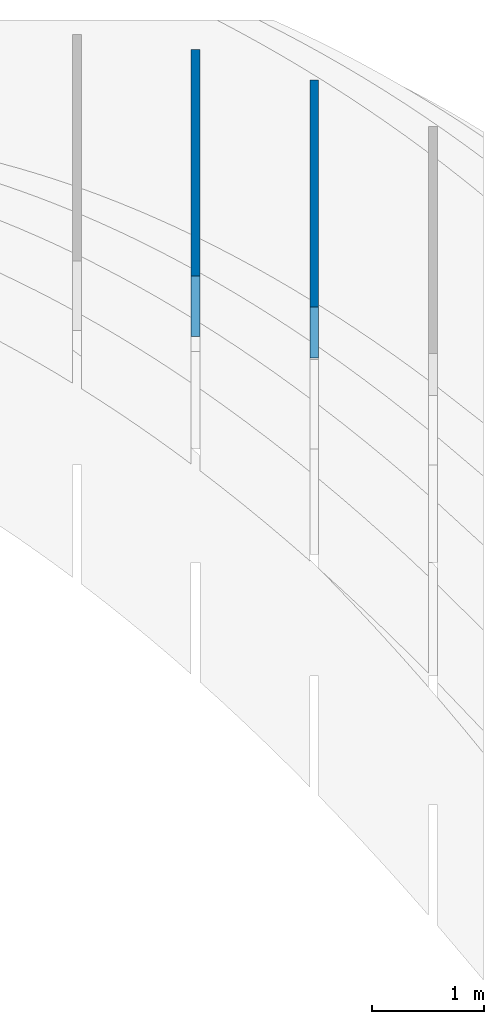
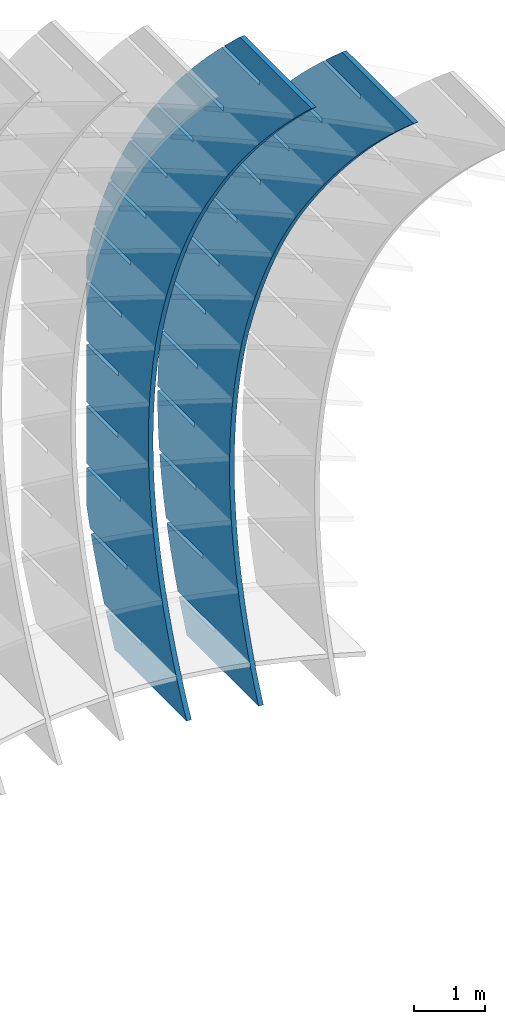
# Not in any storey, part 8 of 9: 2 walls.
"""IFC2X3 building model written with IfcOpenShell, lengths in metres."""

from ifc_helpers import new_model, entity, si_unit, point, direction, frame, frame_2d, origin_with_axes, place, context, project, spatial, polyline, circle_curve, parameter, trimmed, segment, composite_curve, outline, extrude, material, type_object, element, save


model = new_model("IFC2X3")

# Units and contexts
model_context = context("Model", 3, precision=2.54e-06, world=origin_with_axes(), true_north=direction((0.0, 1.0)), identifier="Body")
ifc_project = project(units=[si_unit("LENGTHUNIT", "METRE"), si_unit("AREAUNIT", "SQUARE_METRE"), si_unit("VOLUMEUNIT", "CUBIC_METRE"), si_unit("PLANEANGLEUNIT", "RADIAN")], contexts=[model_context])

# Building
building_placement = place(None, origin_with_axes())
building = spatial("IfcBuilding", under=ifc_project, at=building_placement, Name="Building", CompositionType="ELEMENT")

# Walls
ifc_material = material(Name="MATERIAL")
wall_type = type_object("IfcWallType", Name="WALL", PredefinedType="NOTDEFINED", material=ifc_material)
wall_1_placement = place(None, origin_with_axes())
cartesian_point_1 = entity("IfcCartesianPoint", [3.33628428857508, 0.660800836705799])
cartesian_point_2 = entity("IfcCartesianPoint", [5.89989121669628, 2.3739950625877])
cartesian_point_3 = entity("IfcCartesianPoint", [7.96759101893719, 5.14737190911829])
cartesian_point_4 = entity("IfcCartesianPoint", [9.64855568825393, 9.34702306752498])
cartesian_point_5 = entity("IfcCartesianPoint", [10.5095055595742, 7.50642824001081])
cartesian_point_6 = entity("IfcCartesianPoint", [10.3316593318507, 6.9182703694655])
cartesian_point_7 = entity("IfcCartesianPoint", [9.91130915650263, 7.81692240980345])
cartesian_point_8 = entity("IfcCartesianPoint", [9.83998610693644, 7.7835606022898])
cartesian_point_9 = entity("IfcCartesianPoint", [10.2966458160783, 6.80728367075111])
cartesian_point_10 = entity("IfcCartesianPoint", [9.83148702993814, 5.48062696650699])
cartesian_point_11 = entity("IfcCartesianPoint", [9.4089005920243, 6.38405983491734])
cartesian_point_12 = entity("IfcCartesianPoint", [9.33757754245811, 6.35069802740369])
cartesian_point_13 = entity("IfcCartesianPoint", [9.79200104866843, 5.37920179644498])
cartesian_point_14 = entity("IfcCartesianPoint", [9.2709518727035, 4.1720312154331])
cartesian_point_15 = entity("IfcCartesianPoint", [8.84613322657731, 5.08023624424941])
cartesian_point_16 = entity("IfcCartesianPoint", [8.77481017701111, 5.04687443673576])
cartesian_point_17 = entity("IfcCartesianPoint", [9.22700147500962, 4.08015036618439])
cartesian_point_18 = entity("IfcCartesianPoint", [8.65019291620515, 2.992185833119])
cartesian_point_19 = entity("IfcCartesianPoint", [8.22314206186706, 3.90516302234252])
cartesian_point_20 = entity("IfcCartesianPoint", [8.15181901230087, 3.87180121482886])
cartesian_point_21 = entity("IfcCartesianPoint", [8.60177810208755, 2.90984930468483])
cartesian_point_22 = entity("IfcCartesianPoint", [7.96921016044345, 1.94109081956572])
cartesian_point_23 = entity("IfcCartesianPoint", [7.53992709789357, 2.85884016919665])
cartesian_point_24 = entity("IfcCartesianPoint", [7.46860404832738, 2.825478361683])
cartesian_point_25 = entity("IfcCartesianPoint", [7.91633092990223, 1.8682986119463])
cartesian_point_26 = entity("IfcCartesianPoint", [7.22800360541863, 1.01874617477364])
cartesian_point_27 = entity("IfcCartesianPoint", [6.79648833465683, 1.94126768481181])
cartesian_point_28 = entity("IfcCartesianPoint", [6.72516528509063, 1.90790587729816])
cartesian_point_29 = entity("IfcCartesianPoint", [7.17065995845367, 0.9554982879688])
cartesian_point_30 = entity("IfcCartesianPoint", [6.42657325113035, 0.225151898742356])
cartesian_point_31 = entity("IfcCartesianPoint", [5.99282577215684, 1.152445569188])
cartesian_point_32 = entity("IfcCartesianPoint", [5.92150272259064, 1.11908376167435])
cartesian_point_33 = entity("IfcCartesianPoint", [6.36476518774186, 0.17144833275233])
cartesian_point_34 = entity("IfcCartesianPoint", [5.56491909757877, -0.43969200852788])
cartesian_point_35 = entity("IfcCartesianPoint", [5.1289394103936, 0.492373822325222])
cartesian_point_36 = entity("IfcCartesianPoint", [5.0576163608274, 0.45901201481157])
cartesian_point_37 = entity("IfcCartesianPoint", [5.4986466177668, -0.483851253703113])
cartesian_point_38 = entity("IfcCartesianPoint", [4.64304114476423, -0.975785547036886])
cartesian_point_39 = entity("IfcCartesianPoint", [4.20482924936711, -0.0389475557765274])
cartesian_point_40 = entity("IfcCartesianPoint", [4.13350619980092, -0.0723093632901794])
cartesian_point_41 = entity("IfcCartesianPoint", [4.57230424852848, -1.01040047139752])
cartesian_point_42 = entity("IfcCartesianPoint", [3.66093939268637, -1.38312871678492])
cartesian_point_43 = entity("IfcCartesianPoint", [3.22049528907738, -0.441518565117246])
cartesian_point_44 = entity("IfcCartesianPoint", [3.14917223951118, -0.474880372630899])
cartesian_point_45 = entity("IfcCartesianPoint", [3.58573808002693, -1.4081993203309])
cartesian_point_46 = entity("IfcCartesianPoint", [2.61861384134521, -1.66172151777196])
cartesian_point_47 = entity("IfcCartesianPoint", [2.17593752952439, -0.715339205696935])
cartesian_point_48 = entity("IfcCartesianPoint", [2.10461447995819, -0.748701013210588])
cartesian_point_49 = entity("IfcCartesianPoint", [2.53894811226212, -1.67724780050326])
cartesian_point_50 = entity("IfcCartesianPoint", [1.51600977615583, -1.81144697758717])
cartesian_point_51 = entity("IfcCartesianPoint", [1.07107023636221, -0.860226189035098])
cartesian_point_52 = entity("IfcCartesianPoint", [0.99974718679601, -0.893587996548751])
cartesian_point_53 = entity("IfcCartesianPoint", [1.4318204023056, -1.81730231728527])
cartesian_point_54 = entity("IfcCartesianPoint", [0.860949871320121, -1.84059482751472])
element("IfcWall", 1, at=wall_1_placement, inside=building, type_object=wall_type, context=model_context, shape_type="SweptSolid", body=[
    extrude(entity("IfcArbitraryOpenProfileDef", "AREA", None, entity("IfcCompositeCurve", [entity("IfcCompositeCurveSegment", "CONTINUOUS", True, entity("IfcTrimmedCurve", entity("IfcCircle", entity("IfcAxis2Placement2D", entity("IfcCartesianPoint", [0.0, 8.752599843585]), entity("IfcDirection", [0.0, -1.0])), 8.752599843585), [entity("IfcParameterValue", 0.0), entity("IfcCartesianPoint", [0.0, -8.752599843585])], [entity("IfcParameterValue", 0.391068405592432), cartesian_point_1], True, "PARAMETER")), entity("IfcCompositeCurveSegment", "CONTINUOUS", True, entity("IfcTrimmedCurve", entity("IfcCircle", entity("IfcAxis2Placement2D", entity("IfcCartesianPoint", [0.0936429203069245, 8.28773253450056]), entity("IfcDirection", [0.39126281, -0.92027899])), 8.2876299486663), [entity("IfcParameterValue", 0.0), cartesian_point_1], [entity("IfcParameterValue", 0.374223583295173), cartesian_point_2], True, "PARAMETER")), entity("IfcCompositeCurveSegment", "CONTINUOUS", True, entity("IfcTrimmedCurve", entity("IfcCircle", entity("IfcAxis2Placement2D", entity("IfcCartesianPoint", [-2.30291342409356, 10.6471002357322]), entity("IfcDirection", [0.70408324, -0.71011745])), 11.6503336081365), [entity("IfcParameterValue", 0.0), cartesian_point_2], [entity("IfcParameterValue", 0.298031940766196), cartesian_point_3], True, "PARAMETER")), entity("IfcCompositeCurveSegment", "CONTINUOUS", True, entity("IfcTrimmedCurve", entity("IfcCircle", entity("IfcAxis2Placement2D", entity("IfcCartesianPoint", [-9.94868855610094, 14.7548339304275]), entity("IfcDirection", [0.8812863, -0.47258275])), 20.3296925776517), [entity("IfcParameterValue", 0.0), cartesian_point_3], [entity("IfcParameterValue", 0.22297224709584), cartesian_point_4], True, "PARAMETER")), entity("IfcCompositeCurveSegment", "CONTINUOUS", True, entity("IfcPolyline", [cartesian_point_4, cartesian_point_5])), entity("IfcCompositeCurveSegment", "CONTINUOUS", True, entity("IfcPolyline", [cartesian_point_5, cartesian_point_6])), entity("IfcCompositeCurveSegment", "CONTINUOUS", True, entity("IfcPolyline", [cartesian_point_6, cartesian_point_7])), entity("IfcCompositeCurveSegment", "CONTINUOUS", True, entity("IfcPolyline", [cartesian_point_7, cartesian_point_8])), entity("IfcCompositeCurveSegment", "CONTINUOUS", True, entity("IfcPolyline", [cartesian_point_8, cartesian_point_9])), entity("IfcCompositeCurveSegment", "CONTINUOUS", True, entity("IfcTrimmedCurve", entity("IfcCircle", entity("IfcAxis2Placement2D", entity("IfcCartesianPoint", [-11.5769992031336, 13.7318503522371]), entity("IfcDirection", [0.93309434, -0.35963168])), 22.9435387452076), [entity("IfcParameterValue", 0.0612835566242395), cartesian_point_9], [entity("IfcParameterValue", 0.0), cartesian_point_10], False, "PARAMETER")), entity("IfcCompositeCurveSegment", "CONTINUOUS", True, entity("IfcPolyline", [cartesian_point_10, cartesian_point_11])), entity("IfcCompositeCurveSegment", "CONTINUOUS", True, entity("IfcPolyline", [cartesian_point_11, cartesian_point_12])), entity("IfcCompositeCurveSegment", "CONTINUOUS", True, entity("IfcPolyline", [cartesian_point_12, cartesian_point_13])), entity("IfcCompositeCurveSegment", "CONTINUOUS", True, entity("IfcTrimmedCurve", entity("IfcCircle", entity("IfcAxis2Placement2D", entity("IfcCartesianPoint", [-7.87481118422335, 12.2886655949803]), entity("IfcDirection", [0.90384066, -0.42786921])), 18.9698957418201), [entity("IfcParameterValue", 0.0693247809412823), cartesian_point_13], [entity("IfcParameterValue", 0.0), cartesian_point_14], False, "PARAMETER")), entity("IfcCompositeCurveSegment", "CONTINUOUS", True, entity("IfcPolyline", [cartesian_point_14, cartesian_point_15])), entity("IfcCompositeCurveSegment", "CONTINUOUS", True, entity("IfcPolyline", [cartesian_point_15, cartesian_point_16])), entity("IfcCompositeCurveSegment", "CONTINUOUS", True, entity("IfcPolyline", [cartesian_point_16, cartesian_point_17])), entity("IfcCompositeCurveSegment", "CONTINUOUS", True, entity("IfcTrimmedCurve", entity("IfcCircle", entity("IfcAxis2Placement2D", entity("IfcCartesianPoint", [-4.82060400145122, 10.8309141796685]), entity("IfcDirection", [0.8643156, -0.50294984])), 15.5855071039648), [entity("IfcParameterValue", 0.0790306201356145), cartesian_point_17], [entity("IfcParameterValue", 0.0), cartesian_point_18], False, "PARAMETER")), entity("IfcCompositeCurveSegment", "CONTINUOUS", True, entity("IfcPolyline", [cartesian_point_18, cartesian_point_19])), entity("IfcCompositeCurveSegment", "CONTINUOUS", True, entity("IfcPolyline", [cartesian_point_19, cartesian_point_20])), entity("IfcCompositeCurveSegment", "CONTINUOUS", True, entity("IfcPolyline", [cartesian_point_20, cartesian_point_21])), entity("IfcCompositeCurveSegment", "CONTINUOUS", True, entity("IfcTrimmedCurve", entity("IfcCircle", entity("IfcAxis2Placement2D", entity("IfcCartesianPoint", [-2.52920239324131, 9.48711692777493]), entity("IfcDirection", [0.81200466, -0.58365094])), 12.9290052275162), [entity("IfcParameterValue", 0.0895181356163804), cartesian_point_21], [entity("IfcParameterValue", 0.0), cartesian_point_22], False, "PARAMETER")), entity("IfcCompositeCurveSegment", "CONTINUOUS", True, entity("IfcPolyline", [cartesian_point_22, cartesian_point_23])), entity("IfcCompositeCurveSegment", "CONTINUOUS", True, entity("IfcPolyline", [cartesian_point_23, cartesian_point_24])), entity("IfcCompositeCurveSegment", "CONTINUOUS", True, entity("IfcPolyline", [cartesian_point_24, cartesian_point_25])), entity("IfcCompositeCurveSegment", "CONTINUOUS", True, entity("IfcTrimmedCurve", entity("IfcCircle", entity("IfcAxis2Placement2D", entity("IfcCartesianPoint", [-0.897231518059096, 8.30562807521818]), entity("IfcDirection", [0.74446977, -0.66765617])), 10.9141235856491), [entity("IfcParameterValue", 0.100224490194484), cartesian_point_25], [entity("IfcParameterValue", 0.0), cartesian_point_26], False, "PARAMETER")), entity("IfcCompositeCurveSegment", "CONTINUOUS", True, entity("IfcPolyline", [cartesian_point_26, cartesian_point_27])), entity("IfcCompositeCurveSegment", "CONTINUOUS", True, entity("IfcPolyline", [cartesian_point_27, cartesian_point_28])), entity("IfcCompositeCurveSegment", "CONTINUOUS", True, entity("IfcPolyline", [cartesian_point_28, cartesian_point_29])), entity("IfcCompositeCurveSegment", "CONTINUOUS", True, entity("IfcTrimmedCurve", entity("IfcCircle", entity("IfcAxis2Placement2D", entity("IfcCartesianPoint", [0.178683465632477, 7.33480185791517]), entity("IfcDirection", [0.66011554, -0.75116408])), 9.4648428044894), [entity("IfcParameterValue", 0.110213642371302), cartesian_point_29], [entity("IfcParameterValue", 0.0), cartesian_point_30], False, "PARAMETER")), entity("IfcCompositeCurveSegment", "CONTINUOUS", True, entity("IfcPolyline", [cartesian_point_30, cartesian_point_31])), entity("IfcCompositeCurveSegment", "CONTINUOUS", True, entity("IfcPolyline", [cartesian_point_31, cartesian_point_32])), entity("IfcCompositeCurveSegment", "CONTINUOUS", True, entity("IfcPolyline", [cartesian_point_32, cartesian_point_33])), entity("IfcCompositeCurveSegment", "CONTINUOUS", True, entity("IfcTrimmedCurve", entity("IfcCircle", entity("IfcAxis2Placement2D", entity("IfcCartesianPoint", [0.801917399369377, 6.62299251178352]), entity("IfcDirection", [0.5591252, -0.82908324])), 8.51866760770673), [entity("IfcParameterValue", 0.118233031779909), cartesian_point_33], [entity("IfcParameterValue", 0.0), cartesian_point_34], False, "PARAMETER")), entity("IfcCompositeCurveSegment", "CONTINUOUS", True, entity("IfcPolyline", [cartesian_point_34, cartesian_point_35])), entity("IfcCompositeCurveSegment", "CONTINUOUS", True, entity("IfcPolyline", [cartesian_point_35, cartesian_point_36])), entity("IfcCompositeCurveSegment", "CONTINUOUS", True, entity("IfcPolyline", [cartesian_point_36, cartesian_point_37])), entity("IfcCompositeCurveSegment", "CONTINUOUS", True, entity("IfcTrimmedCurve", entity("IfcCircle", entity("IfcAxis2Placement2D", entity("IfcCartesianPoint", [1.07584512468748, 6.21855427274113]), entity("IfcDirection", [0.44422497, -0.89591527])), 8.03015646722372), [entity("IfcParameterValue", 0.122982293439985), cartesian_point_37], [entity("IfcParameterValue", 0.0), cartesian_point_38], False, "PARAMETER")), entity("IfcCompositeCurveSegment", "CONTINUOUS", True, entity("IfcPolyline", [cartesian_point_38, cartesian_point_39])), entity("IfcCompositeCurveSegment", "CONTINUOUS", True, entity("IfcPolyline", [cartesian_point_39, cartesian_point_40])), entity("IfcCompositeCurveSegment", "CONTINUOUS", True, entity("IfcPolyline", [cartesian_point_40, cartesian_point_41])), entity("IfcCompositeCurveSegment", "CONTINUOUS", True, entity("IfcTrimmedCurve", entity("IfcCircle", entity("IfcAxis2Placement2D", entity("IfcCartesianPoint", [1.10384148312315, 6.1698413767053]), entity("IfcDirection", [0.32067584, -0.947189])), 7.97408972562074), [entity("IfcParameterValue", 0.123558271913987), cartesian_point_41], [entity("IfcParameterValue", 0.0), cartesian_point_42], False, "PARAMETER")), entity("IfcCompositeCurveSegment", "CONTINUOUS", True, entity("IfcPolyline", [cartesian_point_42, cartesian_point_43])), entity("IfcCompositeCurveSegment", "CONTINUOUS", True, entity("IfcPolyline", [cartesian_point_43, cartesian_point_44])), entity("IfcCompositeCurveSegment", "CONTINUOUS", True, entity("IfcPolyline", [cartesian_point_44, cartesian_point_45])), entity("IfcCompositeCurveSegment", "CONTINUOUS", True, entity("IfcTrimmedCurve", entity("IfcCircle", entity("IfcAxis2Placement2D", entity("IfcCartesianPoint", [0.989281316212527, 6.5252080595934]), entity("IfcDirection", [0.19518839, -0.98076577])), 8.34748706990283), [entity("IfcParameterValue", 0.119844445167163), cartesian_point_45], [entity("IfcParameterValue", 0.0), cartesian_point_46], False, "PARAMETER")), entity("IfcCompositeCurveSegment", "CONTINUOUS", True, entity("IfcPolyline", [cartesian_point_46, cartesian_point_47])), entity("IfcCompositeCurveSegment", "CONTINUOUS", True, entity("IfcPolyline", [cartesian_point_47, cartesian_point_48])), entity("IfcCompositeCurveSegment", "CONTINUOUS", True, entity("IfcPolyline", [cartesian_point_48, cartesian_point_49])), entity("IfcCompositeCurveSegment", "CONTINUOUS", True, entity("IfcTrimmedCurve", entity("IfcCircle", entity("IfcAxis2Placement2D", entity("IfcCartesianPoint", [0.841571319033154, 7.2952786297832]), entity("IfcDirection", [0.07385711, -0.99726883])), 9.13166570349469), [entity("IfcParameterValue", 0.113041050513726), cartesian_point_49], [entity("IfcParameterValue", 0.0), cartesian_point_50], False, "PARAMETER")), entity("IfcCompositeCurveSegment", "CONTINUOUS", True, entity("IfcPolyline", [cartesian_point_50, cartesian_point_51])), entity("IfcCompositeCurveSegment", "CONTINUOUS", True, entity("IfcPolyline", [cartesian_point_51, cartesian_point_52])), entity("IfcCompositeCurveSegment", "CONTINUOUS", True, entity("IfcPolyline", [cartesian_point_52, cartesian_point_53])), entity("IfcCompositeCurveSegment", "CONTINUOUS", True, entity("IfcPolyline", [cartesian_point_53, cartesian_point_54])), entity("IfcCompositeCurveSegment", "CONTINUOUS", True, entity("IfcPolyline", [cartesian_point_54, entity("IfcCartesianPoint", [0.0, 0.0])]))], "UNKNOWN")), frame((17.3363837134573, -0.590090071613778, -6.51240052652896), z_axis=(1.0, 0.0, 0.0), x_axis=(0.0, 0.4236958, 0.90580454)), (0.0, 0.0, 1.0), 0.07874),
])
wall_2_placement = place(None, origin_with_axes())
element("IfcWall", 2, at=wall_2_placement, inside=building, type_object=wall_type, context=model_context, shape_type="SweptSolid", body=[
    extrude(outline(composite_curve([segment(trimmed(circle_curve(frame_2d((0.0, 9.20461752347333), x_axis=(0.0, -1.0)), 9.20461752347333), [parameter(0.0), point((0.0, -9.20461752347333))], [parameter(0.378223886313724), point((3.39899345067959, 0.650564257584139))], True, "PARAMETER"), True, "CONTINUOUS"), segment(trimmed(circle_curve(frame_2d((0.329804616442884, 8.14417270659547), x_axis=(0.37901595, -0.92539014)), 8.09778288714246), [parameter(0.0), point((3.39899345067959, 0.650564257584139))], [parameter(0.380067485400107), point((5.95997730454182, 2.32392845145617))], True, "PARAMETER"), True, "CONTINUOUS"), segment(trimmed(circle_curve(frame_2d((-1.56899167584664, 10.0081173696648), x_axis=(0.69985574, -0.71428422)), 10.7578870248005), [parameter(0.0), point((5.95997730454182, 2.32392845145617))], [parameter(0.314335542493863), point((7.966906277324, 5.02827967501169))], True, "PARAMETER"), True, "CONTINUOUS"), segment(trimmed(circle_curve(frame_2d((-5.87202203403603, 12.412597620723), x_axis=(0.88225879, -0.47076473)), 15.6857925630271), [parameter(0.0), point((7.966906277324, 5.02827967501169))], [parameter(0.121982619582007), point((8.76260018330957, 6.7670754229196))], True, "PARAMETER"), True, "CONTINUOUS"), segment(trimmed(circle_curve(frame_2d((-11.2006346012153, 14.4600525420821), x_axis=(0.93311348, -0.35958204)), 21.3942197805393), [parameter(0.0), point((8.76260018330957, 6.7670754229196))], [parameter(0.115561710265485), point((9.51648505550891, 9.12024045297327))], True, "PARAMETER"), True, "CONTINUOUS"), segment(polyline([(9.51648505550891, 9.12024045297327), (10.4783858907177, 7.33033241532919)]), True, "CONTINUOUS"), segment(polyline([(10.4783858907177, 7.33033241532919), (10.320502907352, 6.75738222265186)]), True, "CONTINUOUS"), segment(polyline([(10.320502907352, 6.75738222265186), (9.84961745893748, 7.63360731579705)]), True, "CONTINUOUS"), segment(polyline([(9.84961745893748, 7.63360731579705), (9.78025852247875, 7.59633365843272)]), True, "CONTINUOUS"), segment(polyline([(9.78025852247875, 7.59633365843272), (10.2892170446355, 6.64926207237004)]), True, "CONTINUOUS"), segment(trimmed(circle_curve(frame_2d((-9.64067057274752, 12.4392339366316), x_axis=(0.9399691, -0.34125958)), 20.7538958904215), [parameter(0.0655223084688722), point((10.2892170446355, 6.64926207237004))], [parameter(0.0), point((9.86735019231572, 5.35676823178572))], False, "PARAMETER"), True, "CONTINUOUS"), segment(polyline([(9.86735019231572, 5.35676823178572), (9.3939662676223, 6.23764249728559)]), True, "CONTINUOUS"), segment(polyline([(9.3939662676223, 6.23764249728559), (9.32460733116357, 6.20036883992125)]), True, "CONTINUOUS"), segment(polyline([(9.32460733116357, 6.20036883992125), (9.83106744366923, 5.25794630223454)]), True, "CONTINUOUS"), segment(trimmed(circle_curve(frame_2d((-6.2873191201333, 11.2064294700795), x_axis=(0.90996297, -0.41468951)), 17.1810022239189), [parameter(0.0740579088368077), point((9.83106744366923, 5.25794630223454))], [parameter(0.0), point((9.34675675525165, 4.08164814424143))], False, "PARAMETER"), True, "CONTINUOUS"), segment(polyline([(9.34675675525165, 4.08164814424143), (8.87087888402925, 4.96716315312672)]), True, "CONTINUOUS"), segment(polyline([(8.87087888402925, 4.96716315312672), (8.80151994757052, 4.92988949576239)]), True, "CONTINUOUS"), segment(polyline([(8.80151994757052, 4.92988949576239), (9.30548611354708, 3.99210770146055)]), True, "CONTINUOUS"), segment(trimmed(circle_curve(frame_2d((-3.55337011977067, 9.9495935214569), x_axis=(0.86878094, -0.49519661)), 14.1718672349339), [parameter(0.0842035553852726), point((9.30548611354708, 3.99210770146055))], [parameter(0.0), point((8.75887795728485, 2.93173286356159))], False, "PARAMETER"), True, "CONTINUOUS"), segment(polyline([(8.75887795728485, 2.93173286356159), (8.28050613953367, 3.82188861583252)]), True, "CONTINUOUS"), segment(polyline([(8.28050613953367, 3.82188861583252), (8.21114720307494, 3.78461495846818)]), True, "CONTINUOUS"), segment(polyline([(8.21114720307494, 3.78461495846818), (8.71261942252239, 2.85147390755122)]), True, "CONTINUOUS"), segment(trimmed(circle_curve(frame_2d((-1.53711637428114, 8.79115879582096), x_axis=(0.81382013, -0.58111685)), 11.8463893434335), [parameter(0.0948934985891301), point((8.71261942252239, 2.85147390755122))], [parameter(0.0), point((8.10371379841573, 1.90702238974698))], False, "PARAMETER"), True, "CONTINUOUS"), segment(polyline([(8.10371379841573, 1.90702238974698), (7.62284803413556, 2.80181888540298)]), True, "CONTINUOUS"), segment(polyline([(7.62284803413556, 2.80181888540298), (7.55348909767683, 2.76454522803864)]), True, "CONTINUOUS"), segment(polyline([(7.55348909767683, 2.76454522803864), (8.05246737059518, 1.83604492050655)]), True, "CONTINUOUS"), segment(trimmed(circle_curve(frame_2d((-0.138029806006798, 7.78514932112496), x_axis=(0.74278958, -0.66952493)), 10.1230473262443), [parameter(0.105381578793883), point((8.05246737059518, 1.83604492050655))], [parameter(0.0), point((7.3812642786441, 1.00751672279712))], False, "PARAMETER"), True, "CONTINUOUS"), segment(polyline([(7.3812642786441, 1.00751672279712), (6.89790456783492, 1.9069539618381)]), True, "CONTINUOUS"), segment(polyline([(6.89790456783492, 1.9069539618381), (6.82854563137619, 1.86968030447377)]), True, "CONTINUOUS"), segment(polyline([(6.82854563137619, 1.86968030447377), (7.32502995776543, 0.945820740326554)]), True, "CONTINUOUS"), segment(polyline([(7.32502995776543, 0.945820740326554), (6.85847791484714, 0.47385778738051)]), True, "CONTINUOUS"), segment(polyline([(6.85847791484714, 0.47385778738051), (6.55100611559551, 0.308621711401745)]), True, "CONTINUOUS"), segment(polyline([(6.55100611559551, 0.308621711401745), (6.08335680914643, 1.17882498160744)]), True, "CONTINUOUS"), segment(polyline([(6.08335680914643, 1.17882498160744), (6.0139978726877, 1.1415513242431)]), True, "CONTINUOUS"), segment(polyline([(6.0139978726877, 1.1415513242431), (6.48164717913677, 0.27134805403741)]), True, "CONTINUOUS"), segment(polyline([(6.48164717913677, 0.27134805403741), (5.61537236864489, -0.194190088820954)]), True, "CONTINUOUS"), segment(polyline([(5.61537236864489, -0.194190088820954), (5.18578284161828, 0.605191426578315)]), True, "CONTINUOUS"), segment(polyline([(5.18578284161828, 0.605191426578315), (5.11642390515955, 0.567917769213981)]), True, "CONTINUOUS"), segment(polyline([(5.11642390515955, 0.567917769213981), (5.54601343218616, -0.231463746185287)]), True, "CONTINUOUS"), segment(polyline([(5.54601343218616, -0.231463746185287), (4.67973862169428, -0.697001889043652)]), True, "CONTINUOUS"), segment(polyline([(4.67973862169428, -0.697001889043652), (4.25456619363886, 0.0941602749815233)]), True, "CONTINUOUS"), segment(polyline([(4.25456619363886, 0.0941602749815233), (4.18520725718013, 0.056886617617189)]), True, "CONTINUOUS"), segment(polyline([(4.18520725718013, 0.056886617617189), (4.61037968523555, -0.734275546407987)]), True, "CONTINUOUS"), segment(polyline([(4.61037968523555, -0.734275546407987), (3.74410487474367, -1.19981368926635)]), True, "CONTINUOUS"), segment(polyline([(3.74410487474367, -1.19981368926635), (3.28970686520818, -0.354268473182936)]), True, "CONTINUOUS"), segment(polyline([(3.28970686520818, -0.354268473182936), (3.22034792874944, -0.391542130547271)]), True, "CONTINUOUS"), segment(polyline([(3.22034792874944, -0.391542130547271), (3.67474593828494, -1.23708734663069)]), True, "CONTINUOUS"), segment(polyline([(3.67474593828494, -1.23708734663069), (3.12158791846136, -1.53435578170114)]), True, "CONTINUOUS"), segment(polyline([(3.12158791846136, -1.53435578170114), (2.75973626624862, -1.61193950898155)]), True, "CONTINUOUS"), segment(polyline([(2.75973626624862, -1.61193950898155), (2.26390682279381, -0.689298553016324)]), True, "CONTINUOUS"), segment(polyline([(2.26390682279381, -0.689298553016324), (2.19454788633507, -0.726572210380659)]), True, "CONTINUOUS"), segment(polyline([(2.19454788633507, -0.726572210380659), (2.67856248007879, -1.6272280576035)]), True, "CONTINUOUS"), segment(trimmed(circle_curve(frame_2d((0.93175776380832, 7.93521445977937), x_axis=(0.07219203, -0.99739075)), 9.72068071767797), [parameter(0.108426424197181), point((2.67856248007879, -1.6272280576035))], [parameter(0.0), point((1.63351345090015, -1.76010258354988))], False, "PARAMETER"), True, "CONTINUOUS"), segment(polyline([(1.63351345090015, -1.76010258354988), (1.13515540392276, -0.832756394359642)]), True, "CONTINUOUS"), segment(polyline([(1.13515540392276, -0.832756394359642), (1.06579646746403, -0.870030051723977)]), True, "CONTINUOUS"), segment(polyline([(1.06579646746403, -0.870030051723977), (1.5472855984894, -1.7659865101399)]), True, "CONTINUOUS"), segment(polyline([(1.5472855984894, -1.7659865101399), (0.961900835208643, -1.78990803764465)]), True, "CONTINUOUS"), segment(polyline([(0.961900835208643, -1.78990803764465), (0.0, 0.0)]), True, "CONTINUOUS")], self_intersect="UNKNOWN")), frame((16.2742018952755, -0.396112142243056, -6.51240052652892), z_axis=(1.0, 0.0, 0.0), x_axis=(0.0, 0.4733764, 0.88086025)), (0.0, 0.0, 1.0), 0.07874),
])

save(model, "model.ifc")
